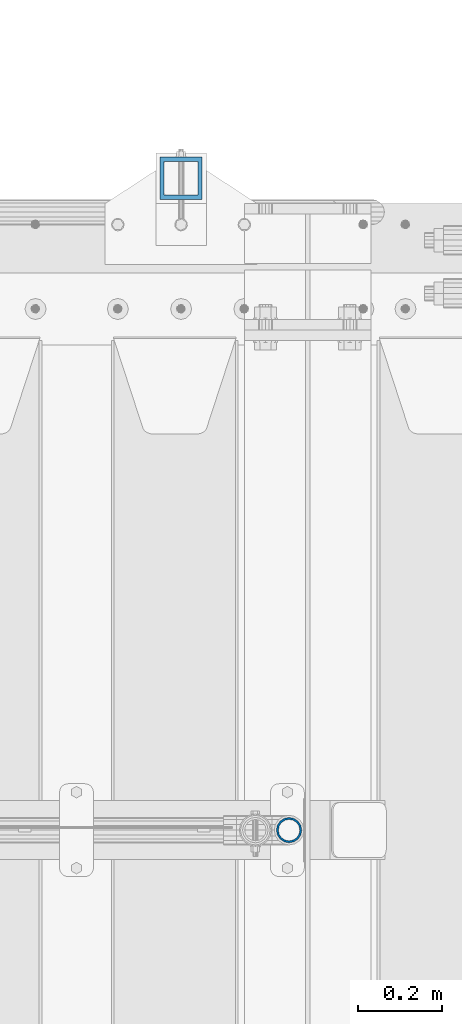
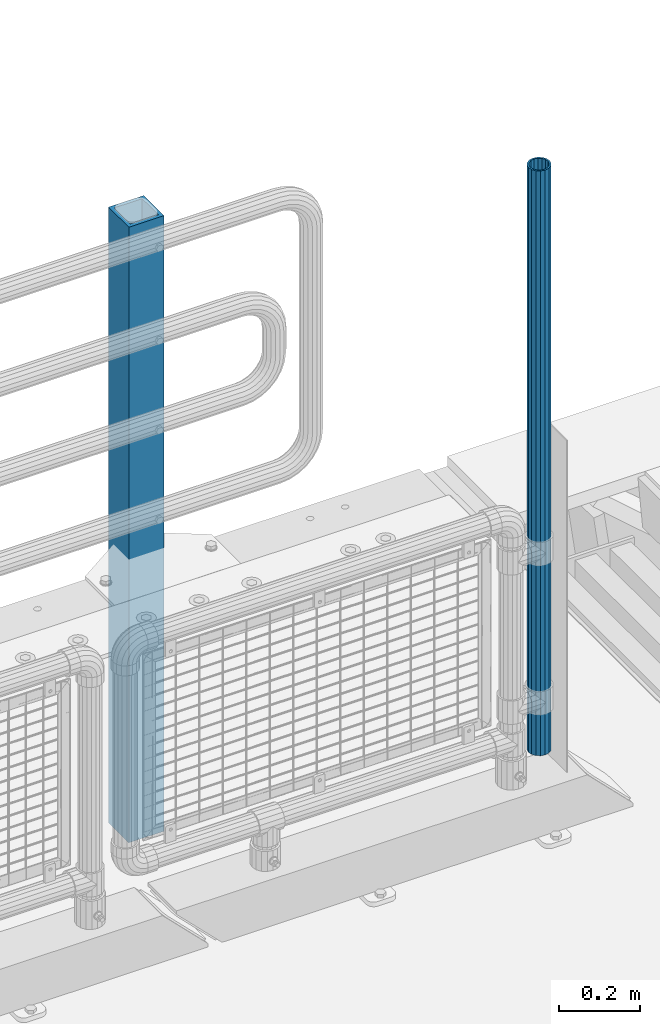
# One storey, part 63 of 257: 2 columns.
"""IFC2X3 building model written with IfcOpenShell, lengths in millimetres."""

from ifc_helpers import new_model, si_unit, frame, origin_with_axes, place, context, subcontext, project, spatial, faceted_brep, material, type_object, element, save


model = new_model("IFC2X3")

# Units and contexts
model_context = context("Model", 3, precision=1e-05, world=origin_with_axes())
body_context = subcontext(model_context, "Body", "Model", "MODEL_VIEW")
ifc_project = project(units=[si_unit("LENGTHUNIT", "METRE", prefix="MILLI"), si_unit("AREAUNIT", "SQUARE_METRE"), si_unit("VOLUMEUNIT", "CUBIC_METRE"), si_unit("MASSUNIT", "GRAM", prefix="KILO"), si_unit("TIMEUNIT", "SECOND"), si_unit("PLANEANGLEUNIT", "RADIAN"), si_unit("SOLIDANGLEUNIT", "STERADIAN"), si_unit("THERMODYNAMICTEMPERATUREUNIT", "DEGREE_CELSIUS"), si_unit("LUMINOUSINTENSITYUNIT", "LUMEN")], contexts=[model_context])

# Site, building, storey
site_placement = place(None, origin_with_axes())
site = spatial("IfcSite", under=ifc_project, at=site_placement, CompositionType="ELEMENT")
building_placement = place(site_placement, origin_with_axes())
building = spatial("IfcBuilding", under=site, at=building_placement, Name="Standard", CompositionType="ELEMENT")
storey_placement = place(building_placement, origin_with_axes())
storey = spatial("IfcBuildingStorey", under=building, at=storey_placement, Name="Undefined", CompositionType="ELEMENT", Elevation=0.0)

# Columns
ifc_material_1 = material(Name="Misc_Undefined")
column_type_1 = type_object("IfcColumnType", PredefinedType="NOTDEFINED")
column_1_placement = place(storey_placement, frame((58751.0, 10664.5, 238.02), z_axis=(-1.0, 0.0, 0.0), x_axis=(0.0, 0.0, 1.0)))
element("IfcColumn", 1, at=column_1_placement, inside=storey, type_object=column_type_1, material=ifc_material_1, context=body_context, shape_type="Brep", body=[
    faceted_brep([(0.0, -25.3500000000004, 0.0), (0.0, -23.4203461491616, 9.70102501045767), (1761.98, -23.4203461491616, 9.70102501045767), (1761.98, -25.3500000000004, 0.0), (0.0, -17.9251569030785, 17.9251569030821), (1761.98, -17.9251569030785, 17.9251569030821), (0.0, -9.70102501045585, 23.4203461491634), (1761.98, -9.70102501045585, 23.4203461491634), (0.0, 0.0, 25.3499999999985), (1761.98, 0.0, 25.3499999999985), (0.0, 9.70102501045585, 23.4203461491634), (1761.98, 9.70102501045585, 23.4203461491634), (0.0, 17.9251569030785, 17.9251569030821), (1761.98, 17.9251569030785, 17.9251569030821), (0.0, 23.4203461491616, 9.70102501045767), (1761.98, 23.4203461491616, 9.70102501045767), (0.0, 25.3500000000004, 0.0), (1761.98, 25.3500000000004, 0.0), (0.0, 23.4203461491616, -9.70102501045767), (1761.98, 23.4203461491616, -9.70102501045767), (0.0, 17.9251569030785, -17.9251569030821), (1761.98, 17.9251569030785, -17.9251569030821), (0.0, 9.70102501045585, -23.4203461491634), (1761.98, 9.70102501045585, -23.4203461491634), (0.0, 0.0, -25.3499999999985), (1761.98, 0.0, -25.3499999999985), (0.0, -9.70102501045585, -23.4203461491634), (1761.98, -9.70102501045585, -23.4203461491634), (0.0, -17.9251569030785, -17.9251569030821), (1761.98, -17.9251569030785, -17.9251569030821), (0.0, -23.4203461491616, -9.70102501045767), (1761.98, -23.4203461491616, -9.70102501045767), (0.0, -30.1499999999996, 0.0), (0.0, -27.8549679052157, -11.5379054858058), (1761.98, -27.8549679052157, -11.5379054858058), (1761.98, -30.1499999999996, 0.0), (0.0, -21.3192694527752, -21.3192694527752), (1761.98, -21.3192694527752, -21.3192694527752), (0.0, -11.5379054858076, -27.8549679052157), (1761.98, -11.5379054858076, -27.8549679052157), (0.0, 0.0, -30.1500000000015), (1761.98, 0.0, -30.1500000000015), (0.0, 11.5379054858076, -27.8549679052157), (1761.98, 11.5379054858076, -27.8549679052157), (0.0, 21.3192694527752, -21.3192694527752), (1761.98, 21.3192694527752, -21.3192694527752), (0.0, 27.8549679052157, -11.5379054858058), (1761.98, 27.8549679052157, -11.5379054858058), (0.0, 30.1499999999996, 0.0), (1761.98, 30.1499999999996, 0.0), (0.0, 27.8549679052157, 11.5379054858058), (1761.98, 27.8549679052157, 11.5379054858058), (0.0, 21.3192694527752, 21.3192694527752), (1761.98, 21.3192694527752, 21.3192694527752), (0.0, 11.5379054858076, 27.8549679052157), (1761.98, 11.5379054858076, 27.8549679052157), (0.0, 0.0, 30.1500000000015), (1761.98, 0.0, 30.1500000000015), (0.0, -11.5379054858076, 27.8549679052157), (1761.98, -11.5379054858076, 27.8549679052157), (0.0, -21.3192694527752, 21.3192694527752), (1761.98, -21.3192694527752, 21.3192694527752), (0.0, -27.8549679052157, 11.5379054858058), (1761.98, -27.8549679052157, 11.5379054858058)], [[[0, 1, 2, 3]], [[1, 4, 5, 2]], [[4, 6, 7, 5]], [[6, 8, 9, 7]], [[8, 10, 11, 9]], [[10, 12, 13, 11]], [[12, 14, 15, 13]], [[14, 16, 17, 15]], [[16, 18, 19, 17]], [[18, 20, 21, 19]], [[20, 22, 23, 21]], [[22, 24, 25, 23]], [[24, 26, 27, 25]], [[26, 28, 29, 27]], [[28, 30, 31, 29]], [[30, 0, 3, 31]], [[32, 33, 34, 35]], [[33, 36, 37, 34]], [[36, 38, 39, 37]], [[38, 40, 41, 39]], [[40, 42, 43, 41]], [[42, 44, 45, 43]], [[44, 46, 47, 45]], [[46, 48, 49, 47]], [[48, 50, 51, 49]], [[50, 52, 53, 51]], [[52, 54, 55, 53]], [[54, 56, 57, 55]], [[56, 58, 59, 57]], [[58, 60, 61, 59]], [[60, 62, 63, 61]], [[62, 32, 35, 63]], [[37, 39, 41, 43, 45, 47, 49, 51, 53, 55, 57, 59, 61, 63, 35, 34], [5, 7, 9, 11, 13, 15, 17, 19, 21, 23, 25, 27, 29, 31, 3, 2]], [[62, 60, 58, 56, 54, 52, 50, 48, 46, 44, 42, 40, 38, 36, 33, 32], [30, 28, 26, 24, 22, 20, 18, 16, 14, 12, 10, 8, 6, 4, 1, 0]]]),
])
ifc_material_2 = material()
column_type_2 = type_object("IfcColumnType", PredefinedType="NOTDEFINED")
column_2_placement = place(storey_placement, frame((58495.0000000001, 12210.0000000002, -844.999999999998), z_axis=(0.0, -1.0, 0.0), x_axis=(0.0, 0.0, 1.0)))
element("IfcColumn", 2, at=column_2_placement, inside=storey, type_object=column_type_2, material=ifc_material_2, context=body_context, shape_type="Brep", body=[
    faceted_brep([(0.0, 40.0, -40.0), (0.0, -40.0, -40.0), (1855.0, -40.0, -40.0), (1855.0, 40.0, -40.0), (0.0, -40.0, 40.0), (1855.0, -40.0, 40.0), (0.0, 40.0, 40.0), (1855.0, 40.0, 40.0), (0.0, 50.0, -50.0), (0.0, 50.0, 50.0), (1855.0, 50.0, 50.0), (1855.0, 50.0, -50.0), (0.0, -50.0, 50.0), (1855.0, -50.0, 50.0), (0.0, -50.0, -50.0), (1855.0, -50.0, -50.0)], [[[0, 1, 2, 3]], [[1, 4, 5, 2]], [[4, 6, 7, 5]], [[6, 0, 3, 7]], [[8, 9, 10, 11]], [[9, 12, 13, 10]], [[12, 14, 15, 13]], [[14, 8, 11, 15]], [[13, 15, 11, 10], [5, 7, 3, 2]], [[14, 12, 9, 8], [6, 4, 1, 0]]]),
])

save(model, "model.ifc")
